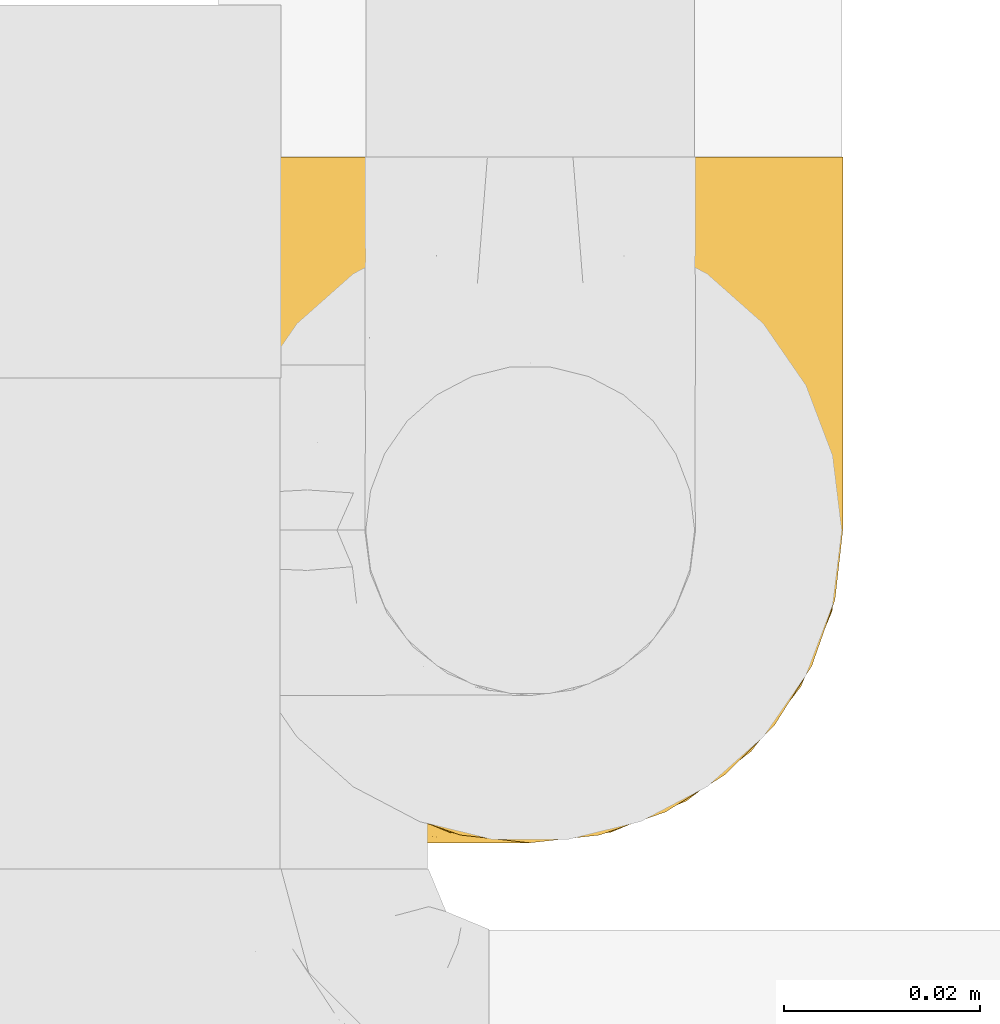
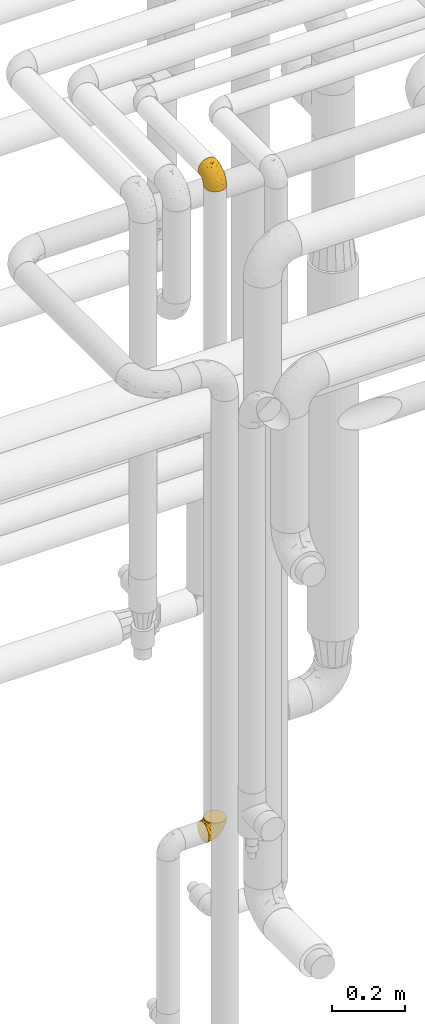
# One storey, part 451 of 827: 2 coverings.
"""IFC2X3 building model written with IfcOpenShell, lengths in millimetres."""

from ifc_helpers import new_model, entity, si_unit, converted_unit, derived_unit, direction, frame, origin, place, context, subcontext, project, spatial, faceted_brep, element, save


model = new_model("IFC2X3")

# Units and contexts
model_context = context("Model", 3, precision=0.01, world=origin(), true_north=direction((6.12303176911189e-17, 1.0)))
body_context = subcontext(model_context, "Body", "Model", "MODEL_VIEW")
ifc_project = project(units=[si_unit("LENGTHUNIT", "METRE", prefix="MILLI"), si_unit("AREAUNIT", "SQUARE_METRE"), si_unit("VOLUMEUNIT", "CUBIC_METRE"), converted_unit("PLANEANGLEUNIT", "DEGREE", entity("IfcRatioMeasure", 0.0174532925199433), si_unit("PLANEANGLEUNIT", "RADIAN"), dimensions=[0, 0, 0, 0, 0, 0, 0]), si_unit("MASSUNIT", "GRAM", prefix="KILO"), derived_unit("MASSDENSITYUNIT", [(si_unit("MASSUNIT", "GRAM", prefix="KILO"), 1), (si_unit("LENGTHUNIT", "METRE"), -3)]), derived_unit("MOMENTOFINERTIAUNIT", [(si_unit("LENGTHUNIT", "METRE"), 4)]), si_unit("TIMEUNIT", "SECOND"), si_unit("FREQUENCYUNIT", "HERTZ"), si_unit("THERMODYNAMICTEMPERATUREUNIT", "DEGREE_CELSIUS"), derived_unit("THERMALTRANSMITTANCEUNIT", [(si_unit("MASSUNIT", "GRAM", prefix="KILO"), 1), (si_unit("THERMODYNAMICTEMPERATUREUNIT", "KELVIN"), -1), (si_unit("TIMEUNIT", "SECOND"), -3)]), derived_unit("VOLUMETRICFLOWRATEUNIT", [(si_unit("LENGTHUNIT", "METRE"), 3), (si_unit("TIMEUNIT", "SECOND"), -1)]), derived_unit("MASSFLOWRATEUNIT", [(si_unit("MASSUNIT", "GRAM", prefix="KILO"), 1), (si_unit("TIMEUNIT", "SECOND"), -1)]), derived_unit("ROTATIONALFREQUENCYUNIT", [(si_unit("TIMEUNIT", "SECOND"), -1)]), si_unit("ELECTRICCURRENTUNIT", "AMPERE"), si_unit("ELECTRICVOLTAGEUNIT", "VOLT"), si_unit("POWERUNIT", "WATT"), si_unit("FORCEUNIT", "NEWTON", prefix="KILO"), si_unit("ILLUMINANCEUNIT", "LUX"), si_unit("LUMINOUSFLUXUNIT", "LUMEN"), si_unit("LUMINOUSINTENSITYUNIT", "CANDELA"), derived_unit("USERDEFINED", [(si_unit("MASSUNIT", "GRAM", prefix="KILO"), -1), (si_unit("LENGTHUNIT", "METRE"), -2), (si_unit("TIMEUNIT", "SECOND"), 3), (si_unit("LUMINOUSFLUXUNIT", "LUMEN"), 1)]), derived_unit("LINEARVELOCITYUNIT", [(si_unit("LENGTHUNIT", "METRE"), 1), (si_unit("TIMEUNIT", "SECOND"), -1)]), si_unit("PRESSUREUNIT", "PASCAL"), derived_unit("USERDEFINED", [(si_unit("LENGTHUNIT", "METRE"), -2), (si_unit("MASSUNIT", "GRAM", prefix="KILO"), 1), (si_unit("TIMEUNIT", "SECOND"), -2)]), derived_unit("LINEARFORCEUNIT", [(si_unit("MASSUNIT", "GRAM", prefix="KILO"), 1), (si_unit("LENGTHUNIT", "METRE"), 1), (si_unit("TIMEUNIT", "SECOND"), -2), (si_unit("LENGTHUNIT", "METRE"), -1)]), derived_unit("PLANARFORCEUNIT", [(si_unit("MASSUNIT", "GRAM", prefix="KILO"), 1), (si_unit("LENGTHUNIT", "METRE"), 1), (si_unit("TIMEUNIT", "SECOND"), -2), (si_unit("LENGTHUNIT", "METRE"), -2)])], contexts=[model_context])

# Site, building, storey
site_placement = place(None, origin())
site = spatial("IfcSite", under=ifc_project, at=site_placement, CompositionType="ELEMENT")
building_placement = place(site_placement, origin())
building = spatial("IfcBuilding", under=site, at=building_placement, CompositionType="ELEMENT")
storey_placement = place(building_placement, frame((0.0, 0.0, 28200.0)))
storey = spatial("IfcBuildingStorey", under=building, at=storey_placement, Name="08", CompositionType="ELEMENT", Elevation=28200.0)

# Coverings
covering_1_placement = place(storey_placement, frame((55931.91, 16236.99, 3160.4)))
element("IfcCovering", 1, at=covering_1_placement, inside=storey, Name=":ADSK_", ObjectType=":ADSK_", PredefinedType="INSULATION", context=body_context, shape_type="Brep", body=[
    faceted_brep([(40.53, 2.39, 1.6), (33.45, 1.6, 1.6), (26.35, 2.39, 1.6), (19.62, 4.75, 1.6), (13.58, 8.55, 1.6), (8.54, 13.59, 1.6), (4.75, 19.63, 1.6), (2.39, 26.36, 1.6), (1.6, 33.45, 1.6), (2.04, 37.35, 1.6), (2.39, 40.54, 1.6), (3.57, 43.9, 1.6), (4.75, 47.27, 1.6), (8.55, 53.31, 1.6), (13.59, 58.35, 1.6), (19.63, 62.14, 1.6), (26.36, 64.5, 1.6), (33.45, 65.3, 1.6), (40.54, 64.5, 1.6), (47.27, 62.14, 1.6), (53.31, 58.34, 1.6), (58.35, 53.3, 1.6), (62.14, 47.26, 1.6), (63.32, 43.89, 1.6), (64.5, 40.53, 1.6), (64.86, 37.35, 1.6), (65.08, 35.4, 1.6), (65.3, 33.45, 1.6), (64.5, 26.35, 1.6), (62.14, 19.62, 1.6), (58.34, 13.58, 1.6), (53.3, 8.54, 1.6), (47.26, 4.75, 1.6), (5.86, 71.45, 23.67), (4.27, 71.45, 27.51), (2.68, 71.45, 31.35), (2.11, 71.45, 35.67), (1.85, 71.45, 37.63), (1.6, 71.45, 39.6), (2.68, 71.45, 47.84), (5.86, 71.45, 55.52), (10.92, 71.45, 62.12), (17.52, 71.45, 67.18), (25.2, 71.45, 70.36), (33.45, 71.45, 71.45), (41.69, 71.45, 70.36), (49.37, 71.45, 67.18), (55.97, 71.45, 62.12), (61.03, 71.45, 55.52), (64.21, 71.45, 47.84), (65.3, 71.45, 39.6), (64.78, 71.45, 35.67), (64.21, 71.45, 31.35), (62.62, 71.45, 27.51), (61.03, 71.45, 23.67), (58.5, 71.45, 20.37), (55.97, 71.45, 17.07), (49.37, 71.45, 12.01), (41.69, 71.45, 8.83), (33.45, 71.45, 7.75), (25.2, 71.45, 8.83), (17.52, 71.45, 12.01), (10.92, 71.45, 17.07), (8.39, 71.45, 20.37), (64.03, 37.48, 33.94), (65.3, 38.54, 20.6), (65.3, 42.01, 24.07), (65.3, 45.49, 27.55), (65.3, 48.97, 31.03), (65.3, 52.45, 34.5), (33.45, 58.08, 68.79), (56.13, 40.84, 53.62), (61.0, 47.91, 50.17), (57.25, 55.67, 58.62), (44.44, 55.18, 67.51), (50.33, 45.13, 61.03), (51.72, 59.19, 64.5), (54.4, 11.67, 17.98), (41.87, 38.17, 61.71), (48.25, 28.82, 52.25), (64.6, 29.48, 16.72), (60.78, 32.11, 39.09), (61.71, 24.68, 25.86), (64.46, 55.82, 44.07), (55.78, 28.37, 44.36), (40.71, 9.18, 31.35), (42.87, 4.95, 17.72), (47.87, 11.17, 29.45), (62.12, 60.89, 52.37), (65.3, 55.35, 35.28), (65.3, 58.25, 36.06), (65.3, 61.15, 36.84), (65.3, 64.05, 37.61), (65.3, 65.9, 38.11), (65.3, 67.75, 38.61), (59.32, 16.27, 14.07), (49.35, 6.97, 13.65), (33.45, 4.25, 14.96), (62.53, 21.84, 13.32), (65.3, 33.94, 3.44), (65.3, 34.44, 5.29), (65.3, 35.43, 8.99), (65.3, 36.2, 11.89), (65.3, 36.98, 14.79), (65.3, 37.76, 17.69), (57.03, 18.84, 29.19), (52.84, 14.39, 28.91), (38.52, 51.68, 68.17), (33.45, 6.91, 28.33), (41.09, 26.05, 53.45), (33.45, 33.38, 58.56), (33.45, 22.05, 50.99), (44.35, 17.7, 43.14), (51.29, 19.21, 39.23), (33.45, 44.71, 66.13), (38.44, 17.7, 45.6), (33.45, 14.48, 39.66), (57.42, 66.98, 18.04), (61.06, 65.01, 22.76), (61.24, 61.98, 21.95), (64.58, 64.85, 32.18), (64.0, 62.15, 29.08), (64.21, 48.67, 20.77), (44.85, 63.81, 4.75), (61.42, 50.71, 11.03), (61.84, 48.45, 6.78), (59.03, 52.85, 5.68), (41.64, 67.6, 7.71), (38.8, 65.48, 4.42), (33.45, 67.1, 5.94), (54.12, 66.68, 14.52), (64.27, 43.2, 11.63), (63.33, 44.92, 6.6), (54.97, 58.1, 7.33), (54.91, 61.92, 12.48), (49.44, 63.17, 7.99), (49.79, 66.68, 11.14), (59.23, 56.7, 14.07), (62.42, 50.86, 15.37), (59.27, 54.42, 10.81), (64.6, 40.7, 7.89), (63.73, 57.76, 26.18), (50.25, 61.34, 5.8), (54.66, 59.9, 9.94), (62.35, 58.0, 22.23), (59.05, 62.43, 18.39), (64.34, 45.83, 17.71), (59.52, 58.99, 16.87), (63.71, 45.9, 13.24), (61.92, 67.3, 24.95), (64.52, 53.12, 26.59), (64.9, 49.43, 26.16), (63.33, 53.9, 22.11), (62.23, 52.92, 17.43), (22.04, 63.81, 4.75), (16.65, 61.35, 5.8), (17.46, 63.17, 7.99), (7.66, 56.72, 14.07), (12.13, 59.87, 10.06), (7.35, 54.39, 11.54), (25.25, 67.59, 7.71), (2.29, 40.71, 7.89), (1.6, 35.43, 8.99), (1.6, 36.2, 11.89), (1.6, 36.98, 14.79), (28.1, 65.48, 4.42), (4.51, 58.19, 22.42), (2.45, 55.78, 27.95), (5.62, 62.46, 22.22), (1.6, 69.6, 39.1), (1.6, 61.15, 36.84), (1.6, 64.05, 37.61), (1.6, 67.75, 38.61), (6.96, 67.39, 21.49), (4.16, 66.16, 26.52), (6.38, 58.11, 18.09), (7.84, 62.44, 18.39), (10.87, 61.95, 13.88), (17.1, 66.68, 11.14), (2.31, 64.85, 32.18), (1.6, 52.45, 34.5), (1.6, 48.97, 31.03), (2.62, 43.18, 11.65), (7.88, 52.88, 5.67), (5.05, 48.46, 6.81), (1.6, 34.44, 5.29), (1.6, 34.93, 7.14), (11.92, 58.11, 7.34), (1.6, 58.25, 36.06), (2.23, 60.72, 31.38), (2.95, 49.13, 19.83), (1.6, 45.49, 27.55), (3.29, 53.71, 22.94), (3.56, 44.93, 6.6), (9.57, 67.04, 17.93), (12.74, 66.6, 14.52), (2.39, 44.91, 17.45), (5.47, 50.72, 11.03), (1.6, 37.76, 17.69), (1.6, 38.54, 20.6), (3.46, 46.39, 12.33), (2.2, 57.7, 30.27), (1.6, 55.35, 35.28), (4.02, 62.73, 25.9), (1.6, 42.01, 24.07), (9.64, 55.67, 58.62), (4.35, 21.85, 13.32), (2.29, 29.49, 16.72), (2.43, 55.82, 44.07), (25.02, 38.17, 61.71), (22.45, 55.18, 67.51), (16.56, 45.12, 61.03), (5.89, 47.92, 50.18), (2.86, 37.47, 33.92), (6.1, 32.11, 39.08), (10.76, 40.85, 53.62), (28.37, 51.68, 68.17), (4.77, 60.89, 52.37), (15.17, 59.19, 64.5), (5.18, 24.69, 25.86), (7.56, 16.28, 14.07), (9.85, 18.85, 29.18), (19.01, 11.19, 29.46), (24.01, 4.95, 17.73), (26.18, 9.19, 31.37), (12.48, 11.68, 17.99), (25.8, 26.05, 53.45), (15.6, 19.23, 39.25), (14.04, 14.4, 28.92), (17.53, 6.97, 13.65), (18.64, 28.8, 52.23), (22.54, 17.7, 43.13), (11.1, 28.37, 44.36), (28.45, 17.7, 45.6)], [[[0, 1, 2, 3, 4, 5, 6, 7, 8, 9, 10, 11, 12, 13, 14, 15, 16, 17, 18, 19, 20, 21, 22, 23, 24, 25, 26, 27, 28, 29, 30, 31, 32]], [[33, 34, 35, 36, 37, 38, 39, 40, 41, 42, 43, 44, 45, 46, 47, 48, 49, 50, 51, 52, 53, 54, 55, 56, 57, 58, 59, 60, 61, 62, 63]], [[64, 65, 66, 67, 68, 69]], [[45, 44, 70]], [[71, 72, 73]], [[74, 75, 76]], [[77, 31, 30]], [[75, 78, 79]], [[27, 80, 28]], [[74, 46, 45]], [[64, 81, 82]], [[46, 76, 47]], [[83, 50, 49]], [[48, 47, 73]], [[71, 79, 84]], [[85, 86, 87]], [[49, 48, 88]], [[83, 69, 89, 90, 91, 92, 93, 94, 50]], [[95, 77, 30]], [[75, 74, 78]], [[87, 86, 96]], [[96, 86, 32]], [[96, 32, 31]], [[0, 86, 97]], [[83, 64, 69]], [[98, 80, 82]], [[73, 72, 88]], [[64, 80, 65]], [[1, 0, 97]], [[80, 27, 99, 100, 101, 102, 103, 104, 65]], [[77, 105, 106]], [[64, 82, 80]], [[70, 107, 45]], [[77, 95, 105]], [[82, 95, 98]], [[95, 30, 29]], [[74, 107, 78]], [[86, 0, 32]], [[72, 71, 81]], [[85, 108, 86]], [[76, 73, 47]], [[71, 84, 81]], [[109, 110, 111]], [[87, 112, 85]], [[79, 109, 112]], [[79, 112, 113]], [[88, 83, 49]], [[64, 83, 72]], [[31, 77, 96]], [[87, 96, 77]], [[98, 95, 29]], [[105, 95, 82]], [[81, 105, 82]], [[105, 84, 113]], [[29, 28, 98]], [[114, 107, 70]], [[80, 98, 28]], [[73, 75, 71]], [[79, 71, 75]], [[74, 76, 46]], [[73, 76, 75]], [[78, 107, 114]], [[45, 107, 74]], [[87, 113, 112]], [[115, 85, 112]], [[109, 79, 78]], [[113, 87, 106]], [[116, 115, 111]], [[116, 108, 85]], [[79, 113, 84]], [[109, 78, 110]], [[115, 109, 111]], [[85, 115, 116]], [[109, 115, 112]], [[72, 81, 64]], [[105, 81, 84]], [[73, 88, 48]], [[83, 88, 72]], [[86, 108, 97]], [[78, 114, 110]], [[113, 106, 105]], [[87, 77, 106]], [[117, 118, 119]], [[52, 120, 54, 53]], [[91, 120, 52]], [[91, 90, 120]], [[90, 121, 120]], [[122, 67, 66]], [[18, 123, 19]], [[124, 125, 126]], [[127, 59, 58]], [[128, 129, 127]], [[130, 57, 117]], [[131, 132, 125]], [[19, 133, 20]], [[128, 18, 17]], [[134, 135, 136]], [[137, 138, 139]], [[131, 103, 140]], [[22, 140, 23]], [[131, 65, 104, 103]], [[99, 27, 26, 25, 24, 101, 100]], [[141, 118, 121]], [[19, 123, 142]], [[52, 51, 50, 94, 93, 92, 91]], [[129, 128, 17]], [[117, 56, 118]], [[135, 134, 143]], [[139, 126, 133]], [[119, 144, 145]], [[127, 135, 123]], [[136, 58, 57]], [[101, 24, 23]], [[124, 138, 146]], [[140, 101, 23]], [[145, 147, 134]], [[140, 132, 131]], [[140, 103, 102, 101]], [[140, 22, 132]], [[146, 148, 124]], [[121, 69, 141]], [[55, 149, 118]], [[150, 151, 152]], [[147, 137, 134]], [[144, 150, 152]], [[152, 151, 122]], [[138, 122, 146]], [[59, 127, 129]], [[123, 18, 128]], [[58, 136, 127]], [[135, 127, 136]], [[121, 90, 89, 69]], [[120, 121, 149]], [[122, 66, 146]], [[153, 122, 138]], [[141, 69, 68]], [[127, 123, 128]], [[123, 135, 142]], [[143, 142, 135]], [[19, 142, 133]], [[66, 65, 146]], [[148, 65, 131]], [[22, 21, 132]], [[125, 132, 21]], [[126, 125, 21]], [[148, 125, 124]], [[21, 20, 126]], [[133, 126, 20]], [[139, 138, 124]], [[153, 138, 137]], [[126, 139, 124]], [[139, 133, 143]], [[147, 153, 137]], [[152, 122, 153]], [[134, 136, 130]], [[137, 139, 143]], [[144, 147, 145]], [[153, 147, 152]], [[65, 148, 146]], [[125, 148, 131]], [[141, 144, 119]], [[55, 54, 149]], [[137, 143, 134]], [[142, 143, 133]], [[130, 117, 145]], [[57, 56, 117]], [[134, 130, 145]], [[57, 130, 136]], [[150, 144, 141]], [[147, 144, 152]], [[141, 68, 150]], [[151, 68, 67]], [[117, 119, 145]], [[141, 119, 118]], [[68, 151, 150]], [[122, 151, 67]], [[118, 56, 55]], [[120, 149, 54]], [[118, 149, 121]], [[154, 155, 156]], [[157, 158, 159]], [[129, 160, 59]], [[161, 162, 163, 164]], [[165, 160, 129]], [[166, 167, 168]], [[169, 38, 37, 36, 35, 170, 171, 172]], [[63, 173, 174]], [[175, 176, 177]], [[60, 178, 61]], [[179, 35, 34, 33]], [[160, 60, 59]], [[180, 167, 181]], [[129, 17, 165]], [[182, 161, 164]], [[183, 13, 184]], [[9, 8, 185, 186, 162, 10]], [[187, 155, 15]], [[188, 179, 189]], [[187, 15, 14]], [[190, 191, 192]], [[182, 193, 161]], [[194, 176, 168]], [[176, 195, 177]], [[196, 190, 197]], [[11, 10, 162]], [[11, 161, 12]], [[187, 14, 183]], [[12, 161, 193]], [[156, 158, 177]], [[165, 17, 16]], [[194, 195, 176]], [[187, 159, 158]], [[179, 174, 189]], [[182, 164, 198, 199]], [[200, 199, 196]], [[193, 184, 13]], [[194, 168, 173]], [[201, 202, 189]], [[16, 154, 165]], [[160, 156, 178]], [[160, 165, 154]], [[178, 60, 160]], [[170, 35, 179]], [[188, 170, 179]], [[189, 174, 203]], [[174, 179, 33]], [[201, 189, 203]], [[181, 192, 191]], [[167, 180, 201]], [[192, 175, 190]], [[159, 190, 157]], [[15, 154, 16]], [[204, 196, 199]], [[204, 191, 190]], [[160, 154, 156]], [[15, 155, 154]], [[158, 155, 187]], [[203, 173, 168]], [[192, 181, 167]], [[190, 196, 204]], [[200, 196, 197]], [[184, 193, 182]], [[13, 12, 193]], [[200, 184, 182]], [[184, 200, 183]], [[187, 183, 197]], [[14, 13, 183]], [[162, 161, 11]], [[63, 62, 173]], [[174, 33, 63]], [[173, 62, 194]], [[174, 173, 203]], [[62, 61, 194]], [[195, 61, 178]], [[61, 195, 194]], [[177, 195, 178]], [[156, 177, 178]], [[175, 192, 166]], [[166, 168, 176]], [[167, 203, 168]], [[175, 166, 176]], [[167, 166, 192]], [[177, 157, 175]], [[190, 175, 157]], [[187, 197, 159]], [[190, 159, 197]], [[177, 158, 157]], [[155, 158, 156]], [[167, 201, 203]], [[200, 197, 183]], [[202, 201, 180]], [[202, 188, 189]], [[199, 200, 182]], [[41, 40, 205]], [[206, 207, 7]], [[208, 38, 169, 172, 171, 170, 188, 202, 180]], [[209, 210, 211]], [[212, 213, 214]], [[212, 215, 205]], [[43, 210, 216]], [[217, 40, 39]], [[216, 114, 70]], [[208, 213, 212]], [[205, 40, 217]], [[218, 42, 41]], [[216, 209, 114]], [[42, 218, 210]], [[214, 213, 219]], [[219, 220, 221]], [[199, 207, 213]], [[213, 207, 219]], [[8, 7, 207]], [[222, 223, 224]], [[4, 225, 5]], [[2, 97, 223]], [[110, 226, 111]], [[225, 220, 5]], [[227, 221, 228]], [[223, 229, 3]], [[2, 223, 3]], [[230, 231, 226]], [[224, 223, 108]], [[42, 210, 43]], [[230, 209, 211]], [[222, 225, 229]], [[38, 208, 39]], [[3, 229, 4]], [[213, 180, 181, 191, 204, 199]], [[220, 206, 6]], [[5, 220, 6]], [[207, 199, 198, 164, 163, 162, 186, 185, 8]], [[212, 214, 215]], [[218, 205, 211]], [[211, 215, 230]], [[226, 110, 209]], [[222, 231, 227]], [[222, 224, 231]], [[213, 208, 180]], [[217, 208, 212]], [[222, 229, 223]], [[225, 4, 229]], [[221, 220, 225]], [[206, 220, 219]], [[228, 221, 225]], [[214, 221, 232]], [[207, 206, 219]], [[44, 43, 70]], [[7, 6, 206]], [[230, 215, 232]], [[211, 205, 215]], [[205, 218, 41]], [[210, 218, 211]], [[43, 216, 70]], [[209, 216, 210]], [[233, 116, 111]], [[230, 232, 227]], [[224, 116, 233]], [[230, 226, 209]], [[224, 108, 116]], [[230, 227, 231]], [[221, 227, 232]], [[233, 226, 231]], [[225, 222, 228]], [[226, 233, 111]], [[224, 233, 231]], [[221, 214, 219]], [[214, 232, 215]], [[208, 217, 39]], [[205, 217, 212]], [[97, 2, 1]], [[97, 108, 223]], [[110, 114, 209]], [[227, 228, 222]]]),
])
covering_2_placement = place(storey_placement, frame((55925.76, 16236.99, 966.55)))
element("IfcCovering", 2, at=covering_2_placement, inside=storey, Name=":ADSK_", ObjectType=":ADSK_", PredefinedType="INSULATION", context=body_context, shape_type="Brep", body=[
    faceted_brep([(1.6, 40.53, 2.39), (1.6, 33.45, 1.6), (1.6, 26.35, 2.39), (1.6, 19.62, 4.75), (1.6, 13.58, 8.55), (1.6, 8.54, 13.59), (1.6, 4.75, 19.63), (1.6, 2.39, 26.36), (1.6, 1.6, 33.45), (1.6, 2.04, 37.35), (1.6, 2.39, 40.54), (1.6, 3.57, 43.9), (1.6, 4.75, 47.27), (1.6, 8.55, 53.31), (1.6, 13.59, 58.35), (1.6, 19.63, 62.14), (1.6, 26.36, 64.5), (1.6, 33.45, 65.3), (1.6, 40.54, 64.5), (1.6, 47.27, 62.14), (1.6, 53.31, 58.34), (1.6, 58.35, 53.3), (1.6, 62.14, 47.26), (1.6, 63.32, 43.89), (1.6, 64.5, 40.53), (1.6, 64.86, 37.35), (1.6, 65.08, 35.4), (1.6, 65.3, 33.45), (1.6, 64.5, 26.35), (1.6, 62.14, 19.62), (1.6, 58.34, 13.58), (1.6, 53.3, 8.54), (1.6, 47.26, 4.75), (23.67, 5.86, 71.45), (27.51, 4.27, 71.45), (31.35, 2.68, 71.45), (35.67, 2.11, 71.45), (37.63, 1.85, 71.45), (39.6, 1.6, 71.45), (47.84, 2.68, 71.45), (55.52, 5.86, 71.45), (62.12, 10.92, 71.45), (67.18, 17.52, 71.45), (70.36, 25.2, 71.45), (71.45, 33.45, 71.45), (70.36, 41.69, 71.45), (67.18, 49.37, 71.45), (62.12, 55.97, 71.45), (55.52, 61.03, 71.45), (47.84, 64.21, 71.45), (39.6, 65.3, 71.45), (35.67, 64.78, 71.45), (31.35, 64.21, 71.45), (27.51, 62.62, 71.45), (23.67, 61.03, 71.45), (20.37, 58.5, 71.45), (17.07, 55.97, 71.45), (12.01, 49.37, 71.45), (8.83, 41.69, 71.45), (7.75, 33.45, 71.45), (8.83, 25.2, 71.45), (12.01, 17.52, 71.45), (17.07, 10.92, 71.45), (20.37, 8.39, 71.45), (33.94, 64.03, 37.48), (20.6, 65.3, 38.54), (24.07, 65.3, 42.01), (27.55, 65.3, 45.49), (31.03, 65.3, 48.97), (34.5, 65.3, 52.45), (68.79, 33.45, 58.08), (53.62, 56.13, 40.84), (50.17, 61.0, 47.91), (58.62, 57.25, 55.67), (67.51, 44.44, 55.18), (61.03, 50.33, 45.13), (64.5, 51.72, 59.19), (17.98, 54.4, 11.67), (61.71, 41.87, 38.17), (52.25, 48.25, 28.82), (16.72, 64.6, 29.48), (39.09, 60.78, 32.11), (25.86, 61.71, 24.68), (44.07, 64.46, 55.82), (44.36, 55.78, 28.37), (31.35, 40.71, 9.18), (17.72, 42.87, 4.95), (29.45, 47.87, 11.17), (52.37, 62.12, 60.89), (35.28, 65.3, 55.35), (36.06, 65.3, 58.25), (36.84, 65.3, 61.15), (37.61, 65.3, 64.05), (38.11, 65.3, 65.9), (38.61, 65.3, 67.75), (14.07, 59.32, 16.27), (13.65, 49.35, 6.97), (14.96, 33.45, 4.25), (13.32, 62.53, 21.84), (3.44, 65.3, 33.94), (5.29, 65.3, 34.44), (8.99, 65.3, 35.43), (11.89, 65.3, 36.2), (14.79, 65.3, 36.98), (17.69, 65.3, 37.76), (29.19, 57.03, 18.84), (28.91, 52.84, 14.39), (68.17, 38.52, 51.68), (28.33, 33.45, 6.91), (53.45, 41.09, 26.05), (58.56, 33.45, 33.38), (50.99, 33.45, 22.05), (43.14, 44.35, 17.7), (39.23, 51.29, 19.21), (66.13, 33.45, 44.71), (45.6, 38.44, 17.7), (39.66, 33.45, 14.48), (18.04, 57.42, 66.98), (22.76, 61.06, 65.01), (21.95, 61.24, 61.98), (32.18, 64.58, 64.85), (29.08, 64.0, 62.15), (20.77, 64.21, 48.67), (4.75, 44.85, 63.81), (11.03, 61.42, 50.71), (6.78, 61.84, 48.45), (5.68, 59.03, 52.85), (7.71, 41.64, 67.6), (4.42, 38.8, 65.48), (5.94, 33.45, 67.1), (14.52, 54.12, 66.68), (11.63, 64.27, 43.2), (6.6, 63.33, 44.92), (7.33, 54.97, 58.1), (12.48, 54.91, 61.92), (7.99, 49.44, 63.17), (11.14, 49.79, 66.68), (14.07, 59.23, 56.7), (15.37, 62.42, 50.86), (10.81, 59.27, 54.42), (7.89, 64.6, 40.7), (26.18, 63.73, 57.76), (5.8, 50.25, 61.34), (9.94, 54.66, 59.9), (22.23, 62.35, 58.0), (18.39, 59.05, 62.43), (17.71, 64.34, 45.83), (16.87, 59.52, 58.99), (13.24, 63.71, 45.9), (24.95, 61.92, 67.3), (26.59, 64.52, 53.12), (26.16, 64.9, 49.43), (22.11, 63.33, 53.9), (17.43, 62.23, 52.92), (4.75, 22.04, 63.81), (5.8, 16.65, 61.35), (7.99, 17.46, 63.17), (14.07, 7.66, 56.72), (10.06, 12.13, 59.87), (11.54, 7.35, 54.39), (7.71, 25.25, 67.59), (7.89, 2.29, 40.71), (8.99, 1.6, 35.43), (11.89, 1.6, 36.2), (14.79, 1.6, 36.98), (4.42, 28.1, 65.48), (22.42, 4.51, 58.19), (27.95, 2.45, 55.78), (22.22, 5.62, 62.46), (36.84, 1.6, 61.15), (37.61, 1.6, 64.05), (38.61, 1.6, 67.75), (39.1, 1.6, 69.6), (21.49, 6.96, 67.39), (26.52, 4.16, 66.16), (18.09, 6.38, 58.11), (18.39, 7.84, 62.44), (13.88, 10.87, 61.95), (11.14, 17.1, 66.68), (32.18, 2.31, 64.85), (34.5, 1.6, 52.45), (31.03, 1.6, 48.97), (11.65, 2.62, 43.18), (5.67, 7.88, 52.88), (6.81, 5.05, 48.46), (5.29, 1.6, 34.44), (7.14, 1.6, 34.93), (7.34, 11.92, 58.11), (36.06, 1.6, 58.25), (31.38, 2.23, 60.72), (19.83, 2.95, 49.13), (27.55, 1.6, 45.49), (22.94, 3.29, 53.71), (6.6, 3.56, 44.93), (17.93, 9.57, 67.04), (14.52, 12.74, 66.6), (17.45, 2.39, 44.91), (11.03, 5.47, 50.72), (17.69, 1.6, 37.76), (20.6, 1.6, 38.54), (12.33, 3.46, 46.39), (25.9, 4.02, 62.73), (30.27, 2.2, 57.7), (35.28, 1.6, 55.35), (24.07, 1.6, 42.01), (58.62, 9.64, 55.67), (13.32, 4.35, 21.85), (16.72, 2.29, 29.49), (44.07, 2.43, 55.82), (61.71, 25.02, 38.17), (67.51, 22.45, 55.18), (61.03, 16.56, 45.12), (50.18, 5.89, 47.92), (33.92, 2.86, 37.47), (39.08, 6.1, 32.11), (53.62, 10.76, 40.85), (68.17, 28.37, 51.68), (52.37, 4.77, 60.89), (64.5, 15.17, 59.19), (25.86, 5.18, 24.69), (14.07, 7.56, 16.28), (29.18, 9.85, 18.85), (29.46, 19.01, 11.19), (17.73, 24.01, 4.95), (31.37, 26.18, 9.19), (17.99, 12.48, 11.68), (53.45, 25.8, 26.05), (39.25, 15.6, 19.23), (28.92, 14.04, 14.4), (13.65, 17.53, 6.97), (52.23, 18.64, 28.8), (43.13, 22.54, 17.7), (44.36, 11.1, 28.37), (45.6, 28.45, 17.7)], [[[0, 1, 2, 3, 4, 5, 6, 7, 8, 9, 10, 11, 12, 13, 14, 15, 16, 17, 18, 19, 20, 21, 22, 23, 24, 25, 26, 27, 28, 29, 30, 31, 32]], [[33, 34, 35, 36, 37, 38, 39, 40, 41, 42, 43, 44, 45, 46, 47, 48, 49, 50, 51, 52, 53, 54, 55, 56, 57, 58, 59, 60, 61, 62, 63]], [[64, 65, 66, 67, 68, 69]], [[45, 44, 70]], [[71, 72, 73]], [[74, 75, 76]], [[77, 31, 30]], [[75, 78, 79]], [[27, 80, 28]], [[74, 46, 45]], [[64, 81, 82]], [[46, 76, 47]], [[83, 50, 49]], [[48, 47, 73]], [[71, 79, 84]], [[85, 86, 87]], [[49, 48, 88]], [[83, 69, 89, 90, 91, 92, 93, 94, 50]], [[95, 77, 30]], [[75, 74, 78]], [[87, 86, 96]], [[96, 86, 32]], [[96, 32, 31]], [[0, 86, 97]], [[83, 64, 69]], [[98, 80, 82]], [[73, 72, 88]], [[64, 80, 65]], [[1, 0, 97]], [[80, 27, 99, 100, 101, 102, 103, 104, 65]], [[77, 105, 106]], [[64, 82, 80]], [[70, 107, 45]], [[77, 95, 105]], [[82, 95, 98]], [[95, 30, 29]], [[74, 107, 78]], [[86, 0, 32]], [[72, 71, 81]], [[85, 108, 86]], [[76, 73, 47]], [[71, 84, 81]], [[109, 110, 111]], [[87, 112, 85]], [[79, 109, 112]], [[79, 112, 113]], [[88, 83, 49]], [[64, 83, 72]], [[31, 77, 96]], [[87, 96, 77]], [[98, 95, 29]], [[105, 95, 82]], [[81, 105, 82]], [[105, 84, 113]], [[29, 28, 98]], [[114, 107, 70]], [[80, 98, 28]], [[73, 75, 71]], [[79, 71, 75]], [[74, 76, 46]], [[73, 76, 75]], [[78, 107, 114]], [[45, 107, 74]], [[87, 113, 112]], [[115, 85, 112]], [[109, 79, 78]], [[113, 87, 106]], [[116, 115, 111]], [[116, 108, 85]], [[79, 113, 84]], [[109, 78, 110]], [[115, 109, 111]], [[85, 115, 116]], [[109, 115, 112]], [[72, 81, 64]], [[105, 81, 84]], [[73, 88, 48]], [[83, 88, 72]], [[86, 108, 97]], [[78, 114, 110]], [[113, 106, 105]], [[87, 77, 106]], [[117, 118, 119]], [[52, 120, 54, 53]], [[91, 120, 52]], [[91, 90, 120]], [[121, 90, 89, 69]], [[122, 67, 66]], [[18, 123, 19]], [[124, 125, 126]], [[127, 59, 58]], [[128, 129, 127]], [[130, 57, 117]], [[131, 132, 125]], [[19, 133, 20]], [[128, 18, 17]], [[134, 135, 136]], [[137, 138, 139]], [[131, 103, 140]], [[22, 140, 23]], [[131, 65, 104, 103]], [[99, 27, 26, 25, 24, 101, 100]], [[141, 118, 121]], [[19, 123, 142]], [[52, 51, 50, 94, 93, 92, 91]], [[129, 128, 17]], [[117, 56, 118]], [[135, 134, 143]], [[139, 126, 133]], [[119, 144, 145]], [[127, 135, 123]], [[136, 58, 57]], [[101, 24, 23]], [[124, 138, 146]], [[140, 101, 23]], [[145, 147, 134]], [[140, 132, 131]], [[140, 103, 102, 101]], [[140, 22, 132]], [[146, 148, 124]], [[121, 69, 141]], [[55, 149, 118]], [[150, 151, 152]], [[147, 137, 134]], [[144, 150, 152]], [[152, 151, 122]], [[138, 122, 146]], [[59, 127, 129]], [[123, 18, 128]], [[58, 136, 127]], [[135, 127, 136]], [[150, 144, 141]], [[120, 121, 149]], [[122, 66, 146]], [[153, 122, 138]], [[141, 69, 68]], [[127, 123, 128]], [[123, 135, 142]], [[143, 142, 135]], [[19, 142, 133]], [[66, 65, 146]], [[148, 65, 131]], [[22, 21, 132]], [[125, 132, 21]], [[126, 125, 21]], [[148, 125, 124]], [[21, 20, 126]], [[133, 126, 20]], [[139, 138, 124]], [[153, 138, 137]], [[126, 139, 124]], [[139, 133, 143]], [[147, 153, 137]], [[152, 122, 153]], [[134, 136, 130]], [[137, 139, 143]], [[144, 147, 145]], [[153, 147, 152]], [[65, 148, 146]], [[125, 148, 131]], [[141, 144, 119]], [[55, 54, 149]], [[137, 143, 134]], [[142, 143, 133]], [[130, 117, 145]], [[57, 56, 117]], [[134, 130, 145]], [[57, 130, 136]], [[90, 121, 120]], [[147, 144, 152]], [[141, 68, 150]], [[151, 68, 67]], [[117, 119, 145]], [[141, 119, 118]], [[68, 151, 150]], [[122, 151, 67]], [[118, 56, 55]], [[120, 149, 54]], [[118, 149, 121]], [[154, 155, 156]], [[157, 158, 159]], [[129, 160, 59]], [[161, 162, 163, 164]], [[165, 160, 129]], [[166, 167, 168]], [[37, 36, 35, 169, 170, 171, 172, 38]], [[63, 173, 174]], [[175, 176, 177]], [[60, 178, 61]], [[179, 35, 34, 33]], [[160, 60, 59]], [[180, 167, 181]], [[129, 17, 165]], [[182, 161, 164]], [[183, 13, 184]], [[9, 8, 185, 186, 162, 10]], [[187, 155, 15]], [[188, 179, 189]], [[187, 15, 14]], [[190, 191, 192]], [[182, 193, 161]], [[194, 176, 168]], [[176, 195, 177]], [[196, 190, 197]], [[11, 10, 162]], [[11, 161, 12]], [[187, 14, 183]], [[12, 161, 193]], [[156, 158, 177]], [[165, 17, 16]], [[194, 195, 176]], [[187, 159, 158]], [[179, 174, 189]], [[182, 164, 198, 199]], [[200, 199, 196]], [[193, 184, 13]], [[174, 173, 201]], [[202, 203, 189]], [[16, 154, 165]], [[160, 156, 178]], [[160, 165, 154]], [[178, 60, 160]], [[169, 35, 179]], [[188, 169, 179]], [[189, 174, 201]], [[174, 179, 33]], [[202, 189, 201]], [[181, 192, 191]], [[167, 180, 202]], [[192, 175, 190]], [[159, 190, 157]], [[15, 154, 16]], [[204, 196, 199]], [[204, 191, 190]], [[160, 154, 156]], [[15, 155, 154]], [[158, 155, 187]], [[201, 173, 168]], [[192, 181, 167]], [[190, 196, 204]], [[200, 196, 197]], [[184, 193, 182]], [[13, 12, 193]], [[200, 184, 182]], [[184, 200, 183]], [[187, 183, 197]], [[14, 13, 183]], [[162, 161, 11]], [[62, 173, 63]], [[174, 33, 63]], [[194, 173, 62]], [[173, 194, 168]], [[62, 61, 194]], [[195, 61, 178]], [[61, 195, 194]], [[177, 195, 178]], [[156, 177, 178]], [[175, 192, 166]], [[166, 168, 176]], [[167, 201, 168]], [[175, 166, 176]], [[167, 166, 192]], [[177, 157, 175]], [[190, 175, 157]], [[187, 197, 159]], [[190, 159, 197]], [[177, 158, 157]], [[155, 158, 156]], [[167, 202, 201]], [[200, 197, 183]], [[203, 202, 180]], [[203, 188, 189]], [[199, 200, 182]], [[41, 40, 205]], [[206, 207, 7]], [[208, 38, 172, 171, 170, 169, 188, 203, 180]], [[209, 210, 211]], [[212, 213, 214]], [[212, 215, 205]], [[43, 210, 216]], [[217, 40, 39]], [[216, 114, 70]], [[208, 213, 212]], [[205, 40, 217]], [[218, 42, 41]], [[216, 209, 114]], [[42, 218, 210]], [[214, 213, 219]], [[219, 220, 221]], [[199, 207, 213]], [[213, 207, 219]], [[8, 7, 207]], [[222, 223, 224]], [[4, 225, 5]], [[2, 97, 223]], [[110, 226, 111]], [[225, 220, 5]], [[227, 221, 228]], [[223, 229, 3]], [[2, 223, 3]], [[230, 231, 226]], [[224, 223, 108]], [[42, 210, 43]], [[230, 209, 211]], [[222, 225, 229]], [[38, 208, 39]], [[3, 229, 4]], [[213, 180, 181, 191, 204, 199]], [[220, 206, 6]], [[5, 220, 6]], [[207, 199, 198, 164, 163, 162, 186, 185, 8]], [[212, 214, 215]], [[218, 205, 211]], [[211, 215, 230]], [[226, 110, 209]], [[222, 231, 227]], [[222, 224, 231]], [[213, 208, 180]], [[217, 208, 212]], [[222, 229, 223]], [[225, 4, 229]], [[221, 220, 225]], [[206, 220, 219]], [[228, 221, 225]], [[214, 221, 232]], [[207, 206, 219]], [[44, 43, 70]], [[7, 6, 206]], [[230, 215, 232]], [[211, 205, 215]], [[205, 218, 41]], [[210, 218, 211]], [[43, 216, 70]], [[209, 216, 210]], [[233, 116, 111]], [[230, 232, 227]], [[224, 116, 233]], [[230, 226, 209]], [[224, 108, 116]], [[230, 227, 231]], [[221, 227, 232]], [[233, 226, 231]], [[225, 222, 228]], [[226, 233, 111]], [[224, 233, 231]], [[221, 214, 219]], [[214, 232, 215]], [[208, 217, 39]], [[205, 217, 212]], [[97, 2, 1]], [[97, 108, 223]], [[110, 114, 209]], [[227, 228, 222]]]),
])

save(model, "model.ifc")
